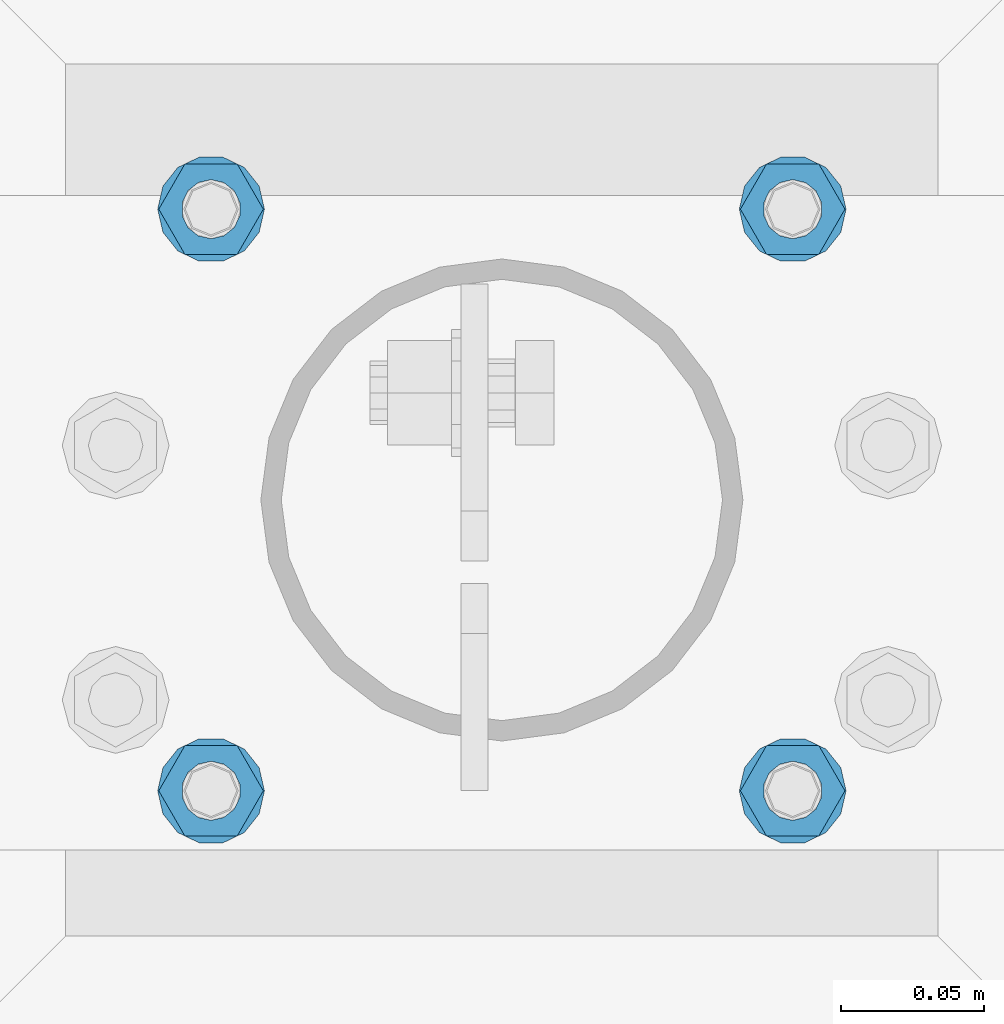
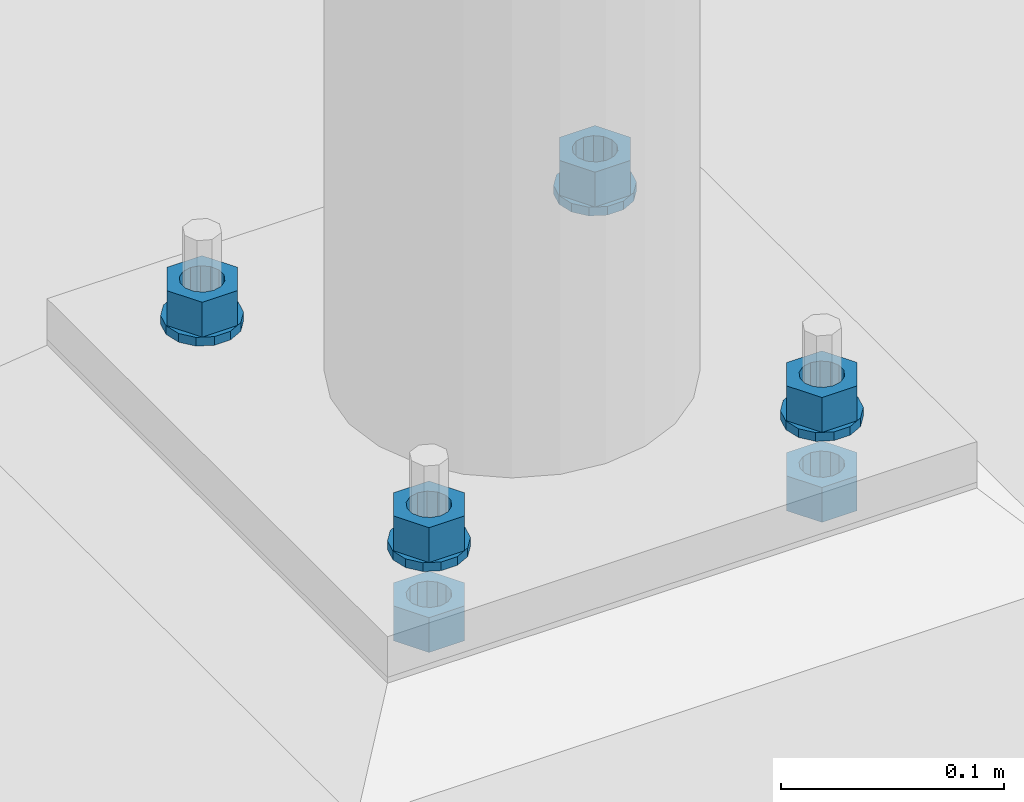
# One storey, part 627 of 975: 10 beams.
"""IFC2X3 building model written with IfcOpenShell, lengths in millimetres."""

import ifcopenshell
import ifcopenshell.guid

model = None  # the IFC model being written
_history = None  # IfcOwnerHistory: only IFC2X3 demands one
_inside = {}  # id of a spatial element -> (the spatial element, [elements in it])
_under = {}  # id of a project, library or spatial element -> (it, [spatial elements below it])
_declared = {}  # id of a project -> (the project, [libraries it declares])
_typed = {}  # id of a type object -> (the type object, [elements of that type])
_made_of = {}  # id of a material, layer set ... -> (it, [elements and type objects made of it])


def new_model(schema):
    """Start an empty IFC model of exactly this schema.

    Asked for "IFC4X3", IfcOpenShell would pick the latest addendum, in which some entities
    have other attributes; the version numbers below select the first issue.
    IFC2X3 requires an IfcOwnerHistory on every rooted entity: one is made here for all.
    """
    global model, _history
    if schema == "IFC4X3":
        model = ifcopenshell.file(schema_version=(4, 3, 0, 0))
    else:
        model = ifcopenshell.file(schema=schema)
    _inside.clear()
    _under.clear()
    _declared.clear()
    _typed.clear()
    _made_of.clear()
    _history = None
    if model.schema == "IFC2X3":
        org = make("IfcOrganization", Name="unknown")
        user = make(
            "IfcPersonAndOrganization",
            ThePerson=make("IfcPerson", FamilyName="unknown"),
            TheOrganization=org,
        )
        app = make(
            "IfcApplication",
            ApplicationDeveloper=org,
            Version="unknown",
            ApplicationFullName="unknown",
            ApplicationIdentifier="unknown",
        )
        _history = make(
            "IfcOwnerHistory",
            OwningUser=user,
            OwningApplication=app,
            ChangeAction="ADDED",
            CreationDate=0,
        )
    return model


def make(cls, **values):
    """One entity of the class cls with the attributes given. An attribute that is None is left unset."""
    return model.create_entity(
        cls, **{name: value for name, value in values.items() if value is not None}
    )


def rooted(cls, **values):
    """An entity with a GlobalId (a new one), such as an element, a storey or a relation."""
    return make(cls, GlobalId=ifcopenshell.guid.new(), OwnerHistory=_history, **values)


def si_unit(unit_type, name, prefix=None):
    """IfcSIUnit, for example si_unit("LENGTHUNIT", "METRE", prefix="MILLI")."""
    return make("IfcSIUnit", UnitType=unit_type, Prefix=prefix, Name=name)


def assignment(units):
    """IfcUnitAssignment: the units of a project."""
    return None if units is None else make("IfcUnitAssignment", Units=units)


def point(xyz):
    """IfcCartesianPoint."""
    return None if xyz is None else make("IfcCartesianPoint", Coordinates=xyz)


def direction(xyz):
    """IfcDirection."""
    return None if xyz is None else make("IfcDirection", DirectionRatios=xyz)


def frame(location, z_axis=None, x_axis=None):
    """IfcAxis2Placement3D, a coordinate frame: its origin and axes. An axis left out is left unset."""
    return make(
        "IfcAxis2Placement3D",
        Location=point(location),
        Axis=direction(z_axis),
        RefDirection=direction(x_axis),
    )


def origin_with_axes():
    """The frame at (0, 0, 0) with the z axis (0, 0, 1) and the x axis (1, 0, 0) written out."""
    return frame((0.0, 0.0, 0.0), z_axis=(0.0, 0.0, 1.0), x_axis=(1.0, 0.0, 0.0))


def place(relative_to, where):
    """IfcLocalPlacement: puts the frame where relative to a parent placement (None: the world)."""
    return make(
        "IfcLocalPlacement", PlacementRelTo=relative_to, RelativePlacement=where
    )


def context(
    kind, dimensions, precision=None, world=None, true_north=None, identifier=None
):
    """IfcGeometricRepresentationContext, for example the 3D "Model" context."""
    return make(
        "IfcGeometricRepresentationContext",
        ContextIdentifier=identifier,
        ContextType=kind,
        CoordinateSpaceDimension=dimensions,
        Precision=precision,
        WorldCoordinateSystem=world,
        TrueNorth=true_north,
    )


def subcontext(parent, identifier, kind, view, scale=None):
    """IfcGeometricRepresentationSubContext, for example "Body" below "Model"."""
    return make(
        "IfcGeometricRepresentationSubContext",
        ContextIdentifier=identifier,
        ContextType=kind,
        ParentContext=parent,
        TargetScale=scale,
        TargetView=view,
    )


def project(units=None, contexts=None):
    """IfcProject with its units and contexts."""
    return rooted(
        "IfcProject",
        Name="project",
        RepresentationContexts=contexts,
        UnitsInContext=assignment(units),
    )


def spatial(cls, under=None, at=None, **own):
    """A site, building, storey or space (cls), placed at a placement, below another one or the project."""
    s = rooted(cls, ObjectPlacement=at, **own)
    if under is not None:
        _under.setdefault(under.id(), (under, []))[1].append(s)
    return s


def faces_of(points, faces, orient=None, outer=None):
    """IfcFace entities. A face is a list of loops; a loop is a list of indices into points, from 0.

    orient and outer hold one flag for each loop. By default every Orientation is true, the
    first loop of a face is its IfcFaceOuterBound and the others are IfcFaceBound.
    """
    made = []
    for i, loops in enumerate(faces):
        bounds = []
        for j, loop in enumerate(loops):
            is_outer = j == 0 if outer is None else outer[i][j]
            bounds.append(
                make(
                    "IfcFaceOuterBound" if is_outer else "IfcFaceBound",
                    Bound=make("IfcPolyLoop", Polygon=[points[k] for k in loop]),
                    Orientation=True if orient is None else orient[i][j],
                )
            )
        made.append(make("IfcFace", Bounds=bounds))
    return made


def faceted_brep(points, faces, orient=None, outer=None, voids=None):
    """IfcFacetedBrep: a solid bounded by flat faces; with voids (closed shells), ...WithVoids."""
    shared = [point(p) for p in points]
    hull = make("IfcClosedShell", CfsFaces=faces_of(shared, faces, orient, outer))
    if voids is None:
        return make("IfcFacetedBrep", Outer=hull)
    return make(
        "IfcFacetedBrepWithVoids",
        Outer=hull,
        Voids=[
            make(cls, CfsFaces=faces_of(shared, fs, o, b)) for cls, fs, o, b in voids
        ],
    )


def shape(context_of_items, identifier, shape_type, items):
    """IfcShapeRepresentation: the items that make up one representation, for example the "Body"."""
    return make(
        "IfcShapeRepresentation",
        ContextOfItems=context_of_items,
        RepresentationIdentifier=identifier,
        RepresentationType=shape_type,
        Items=items,
    )


def material(Name=None, Category=None):
    """IfcMaterial."""
    return make("IfcMaterial", Name=Name, Category=Category)


def made_of(thing, what):
    """Note that an element or type object is made of a material, layer set ...; save() writes the relation."""
    if what is not None:
        _made_of.setdefault(what.id(), (what, []))[1].append(thing)
    return thing


def type_object(cls, material=None, **own):
    """A type object (cls), such as IfcWallType, which elements share."""
    return made_of(rooted(cls, **own), material)


def element(
    cls,
    number,
    at=None,
    inside=None,
    cuts=None,
    type_object=None,
    material=None,
    context=None,
    identifier="Body",
    shape_type=None,
    held_by="IfcProductDefinitionShape",
    body=None,
    shapes=None,
    **own,
):
    """One element of the class cls, such as IfcWall. Its Tag is "e" and its number.

    at: its placement. inside: the storey or other place that contains it. cuts: it is an
    opening in that element (IfcRelVoidsElement). A single representation is given by context,
    identifier, shape_type and body (its items); several are given by shapes. held_by: the class
    of the entity that holds the representations. save() writes the other relations.
    """
    e = rooted(cls, Tag="e%d" % number, ObjectPlacement=at, **own)
    if body is not None:
        shapes = [shape(context, identifier, shape_type, body)]
    if shapes is not None:
        e.Representation = make(held_by, Representations=shapes)
    if inside is not None:
        _inside.setdefault(inside.id(), (inside, []))[1].append(e)
    if cuts is not None:
        rooted(
            "IfcRelVoidsElement", RelatingBuildingElement=cuts, RelatedOpeningElement=e
        )
    if type_object is not None:
        _typed.setdefault(type_object.id(), (type_object, []))[1].append(e)
    return made_of(e, material)


def aggregate(whole, parts):
    """IfcRelAggregates: a whole, such as a stair, and the parts it consists of."""
    return rooted("IfcRelAggregates", RelatingObject=whole, RelatedObjects=parts)


def save(model, path):
    """Write the relations noted so far, then the file.

    IfcRelAggregates (storeys below a building ...), IfcRelContainedInSpatialStructure (elements
    in a storey), IfcRelDefinesByType, IfcRelAssociatesMaterial and IfcRelDeclares: one each for
    every whole, place, type object, material and project.
    """
    for whole, parts in _under.values():
        aggregate(whole, parts)
    for where, things in _inside.values():
        rooted(
            "IfcRelContainedInSpatialStructure",
            RelatedElements=things,
            RelatingStructure=where,
        )
    for kind, things in _typed.values():
        rooted("IfcRelDefinesByType", RelatedObjects=things, RelatingType=kind)
    for what, things in _made_of.values():
        rooted("IfcRelAssociatesMaterial", RelatedObjects=things, RelatingMaterial=what)
    for by, libraries in _declared.values():
        rooted("IfcRelDeclares", RelatingContext=by, RelatedDefinitions=libraries)
    model.write(path)


model = new_model("IFC2X3")

# Units and contexts
model_context = context("Model", 3, precision=1e-05, world=origin_with_axes())
body_context = subcontext(model_context, "Body", "Model", "MODEL_VIEW")
ifc_project = project(units=[si_unit("LENGTHUNIT", "METRE", prefix="MILLI"), si_unit("AREAUNIT", "SQUARE_METRE"), si_unit("VOLUMEUNIT", "CUBIC_METRE"), si_unit("MASSUNIT", "GRAM", prefix="KILO"), si_unit("TIMEUNIT", "SECOND"), si_unit("PLANEANGLEUNIT", "RADIAN"), si_unit("SOLIDANGLEUNIT", "STERADIAN"), si_unit("THERMODYNAMICTEMPERATUREUNIT", "DEGREE_CELSIUS"), si_unit("LUMINOUSINTENSITYUNIT", "LUMEN")], contexts=[model_context])

# Site, building, storey
site_placement = place(None, origin_with_axes())
site = spatial("IfcSite", under=ifc_project, at=site_placement, CompositionType="ELEMENT")
building_placement = place(site_placement, origin_with_axes())
building = spatial("IfcBuilding", under=site, at=building_placement, Name="Undefined", CompositionType="ELEMENT")
storey_placement = place(building_placement, origin_with_axes())
storey = spatial("IfcBuildingStorey", under=building, at=storey_placement, Name="Undefined", CompositionType="ELEMENT", Elevation=0.0)

# Beams
ifc_material = material(Name="STEEL/A36")
beam_type_1 = type_object("IfcBeamType", Name="3/4_WASHER", PredefinedType="NOTDEFINED")
beam_1_placement = place(storey_placement, frame((18757.9000015259, 20545.4250030518, -236.537499999998), z_axis=(0.0, -1.0, 0.0), x_axis=(0.0, 0.0, -1.0)))
element("IfcBeam", 1, at=beam_1_placement, inside=storey, type_object=beam_type_1, material=ifc_material, Name="WASHER", ObjectType="3/4_WASHER", context=body_context, shape_type="Brep", body=[
    faceted_brep([(0.0, -18.6499996185303, 0.0), (0.0, -16.8030690426876, -8.09193156902904), (4.76250000000073, -16.8030690426876, -8.09193156902904), (4.76250000000073, -18.6499996185303, 0.0), (0.0, -11.6280845668225, -14.5811568497838), (4.76250000000073, -11.6280845668225, -14.5811568497838), (0.0, -4.15001533340001, -18.1824051902857), (4.76250000000073, -4.15001533340001, -18.1824051902857), (0.0, 4.15001533340001, -18.1824051902857), (4.76250000000073, 4.15001533340001, -18.1824051902857), (0.0, 11.6280845668234, -14.5811568497838), (4.76250000000073, 11.6280845668234, -14.5811568497838), (0.0, 16.8030690426876, -8.09193156902904), (4.76250000000073, 16.8030690426876, -8.09193156902904), (0.0, 18.6499996185303, 0.0), (4.76250000000073, 18.6499996185303, 0.0), (0.0, 16.8030690426876, 8.09193156902904), (4.76250000000073, 16.8030690426876, 8.09193156902904), (0.0, 11.6280845668225, 14.5811568497838), (4.76250000000073, 11.6280845668225, 14.5811568497838), (0.0, 4.15001533340001, 18.1824051902857), (4.76250000000073, 4.15001533340001, 18.1824051902857), (0.0, -4.15001533340001, 18.1824051902857), (4.76250000000073, -4.15001533340001, 18.1824051902857), (0.0, -11.6280845668234, 14.5811568497838), (4.76250000000073, -11.6280845668234, 14.5811568497838), (0.0, -16.8030690426876, 8.09193156902904), (4.76250000000073, -16.8030690426876, 8.09193156902904), (0.0, 0.0, 10.3199996948242), (0.0, 4.47768005528269, 9.29799844179911), (4.76250000000073, 4.47768005528269, 9.29799844179911), (4.76250000000073, 0.0, 10.3199996948242), (0.0, 8.06850066047446, 6.43441456490817), (4.76250000000073, 8.06850066047446, 6.43441456490817), (0.0, 10.0612557561917, 2.29641597052117), (4.76250000000073, 10.0612557561917, 2.29641597052117), (0.0, 10.0612557561917, -2.29641597052117), (4.76250000000073, 10.0612557561917, -2.29641597052117), (0.0, 8.06850066047446, -6.43441456490814), (4.76250000000073, 8.06850066047446, -6.43441456490814), (0.0, 4.47768005528269, -9.29799844179908), (4.76250000000073, 4.47768005528269, -9.29799844179908), (0.0, 0.0, -10.3199996948242), (4.76250000000073, 0.0, -10.3199996948242), (0.0, -4.47768005528269, -9.29799844179911), (4.76250000000073, -4.47768005528269, -9.29799844179911), (0.0, -8.06850066047446, -6.43441456490817), (4.76250000000073, -8.06850066047446, -6.43441456490817), (0.0, -10.0612557561917, -2.29641597052117), (4.76250000000073, -10.0612557561917, -2.29641597052117), (0.0, -10.0612557561917, 2.29641597052117), (4.76250000000073, -10.0612557561917, 2.29641597052117), (0.0, -8.06850066047446, 6.43441456490814), (4.76250000000073, -8.06850066047446, 6.43441456490814), (0.0, -4.47768005528269, 9.29799844179908), (4.76250000000073, -4.47768005528269, 9.29799844179908)], [[[0, 1, 2, 3]], [[1, 4, 5, 2]], [[4, 6, 7, 5]], [[6, 8, 9, 7]], [[8, 10, 11, 9]], [[10, 12, 13, 11]], [[12, 14, 15, 13]], [[14, 16, 17, 15]], [[16, 18, 19, 17]], [[18, 20, 21, 19]], [[20, 22, 23, 21]], [[22, 24, 25, 23]], [[24, 26, 27, 25]], [[26, 0, 3, 27]], [[28, 29, 30, 31]], [[29, 32, 33, 30]], [[32, 34, 35, 33]], [[34, 36, 37, 35]], [[36, 38, 39, 37]], [[38, 40, 41, 39]], [[40, 42, 43, 41]], [[42, 44, 45, 43]], [[44, 46, 47, 45]], [[46, 48, 49, 47]], [[48, 50, 51, 49]], [[50, 52, 53, 51]], [[52, 54, 55, 53]], [[54, 28, 31, 55]], [[5, 7, 9, 11, 13, 15, 17, 19, 21, 23, 25, 27, 3, 2], [33, 35, 37, 39, 41, 43, 45, 47, 49, 51, 53, 55, 31, 30]], [[26, 24, 22, 20, 18, 16, 14, 12, 10, 8, 6, 4, 1, 0], [54, 52, 50, 48, 46, 44, 42, 40, 38, 36, 34, 32, 29, 28]]]),
])
beam_2_placement = place(storey_placement, frame((18961.0999984741, 20545.4250030518, -236.537499999998), z_axis=(0.0, 1.0, 0.0), x_axis=(0.0, 0.0, -1.0)))
element("IfcBeam", 2, at=beam_2_placement, inside=storey, type_object=beam_type_1, material=ifc_material, Name="WASHER", ObjectType="3/4_WASHER", context=body_context, shape_type="Brep", body=[
    faceted_brep([(0.0, -18.6499996185303, 0.0), (0.0, -16.8030690426876, -8.09193156902904), (4.76250000000073, -16.8030690426876, -8.09193156902904), (4.76250000000073, -18.6499996185303, 0.0), (0.0, -11.6280845668225, -14.5811568497838), (4.76250000000073, -11.6280845668225, -14.5811568497838), (0.0, -4.15001533340001, -18.1824051902857), (4.76250000000073, -4.15001533340001, -18.1824051902857), (0.0, 4.15001533340001, -18.1824051902857), (4.76250000000073, 4.15001533340001, -18.1824051902857), (0.0, 11.6280845668234, -14.5811568497838), (4.76250000000073, 11.6280845668234, -14.5811568497838), (0.0, 16.8030690426876, -8.09193156902904), (4.76250000000073, 16.8030690426876, -8.09193156902904), (0.0, 18.6499996185303, 0.0), (4.76250000000073, 18.6499996185303, 0.0), (0.0, 16.8030690426876, 8.09193156902904), (4.76250000000073, 16.8030690426876, 8.09193156902904), (0.0, 11.6280845668225, 14.5811568497838), (4.76250000000073, 11.6280845668225, 14.5811568497838), (0.0, 4.15001533340001, 18.1824051902857), (4.76250000000073, 4.15001533340001, 18.1824051902857), (0.0, -4.15001533340001, 18.1824051902857), (4.76250000000073, -4.15001533340001, 18.1824051902857), (0.0, -11.6280845668234, 14.5811568497838), (4.76250000000073, -11.6280845668234, 14.5811568497838), (0.0, -16.8030690426876, 8.09193156902904), (4.76250000000073, -16.8030690426876, 8.09193156902904), (0.0, 0.0, 10.3199996948242), (0.0, 4.47768005528269, 9.29799844179911), (4.76250000000073, 4.47768005528269, 9.29799844179911), (4.76250000000073, 0.0, 10.3199996948242), (0.0, 8.06850066047446, 6.43441456490817), (4.76250000000073, 8.06850066047446, 6.43441456490817), (0.0, 10.0612557561917, 2.29641597052117), (4.76250000000073, 10.0612557561917, 2.29641597052117), (0.0, 10.0612557561917, -2.29641597052117), (4.76250000000073, 10.0612557561917, -2.29641597052117), (0.0, 8.06850066047446, -6.43441456490814), (4.76250000000073, 8.06850066047446, -6.43441456490814), (0.0, 4.47768005528269, -9.29799844179908), (4.76250000000073, 4.47768005528269, -9.29799844179908), (0.0, 0.0, -10.3199996948242), (4.76250000000073, 0.0, -10.3199996948242), (0.0, -4.47768005528269, -9.29799844179911), (4.76250000000073, -4.47768005528269, -9.29799844179911), (0.0, -8.06850066047446, -6.43441456490817), (4.76250000000073, -8.06850066047446, -6.43441456490817), (0.0, -10.0612557561917, -2.29641597052117), (4.76250000000073, -10.0612557561917, -2.29641597052117), (0.0, -10.0612557561917, 2.29641597052117), (4.76250000000073, -10.0612557561917, 2.29641597052117), (0.0, -8.06850066047446, 6.43441456490814), (4.76250000000073, -8.06850066047446, 6.43441456490814), (0.0, -4.47768005528269, 9.29799844179908), (4.76250000000073, -4.47768005528269, 9.29799844179908)], [[[0, 1, 2, 3]], [[1, 4, 5, 2]], [[4, 6, 7, 5]], [[6, 8, 9, 7]], [[8, 10, 11, 9]], [[10, 12, 13, 11]], [[12, 14, 15, 13]], [[14, 16, 17, 15]], [[16, 18, 19, 17]], [[18, 20, 21, 19]], [[20, 22, 23, 21]], [[22, 24, 25, 23]], [[24, 26, 27, 25]], [[26, 0, 3, 27]], [[28, 29, 30, 31]], [[29, 32, 33, 30]], [[32, 34, 35, 33]], [[34, 36, 37, 35]], [[36, 38, 39, 37]], [[38, 40, 41, 39]], [[40, 42, 43, 41]], [[42, 44, 45, 43]], [[44, 46, 47, 45]], [[46, 48, 49, 47]], [[48, 50, 51, 49]], [[50, 52, 53, 51]], [[52, 54, 55, 53]], [[54, 28, 31, 55]], [[5, 7, 9, 11, 13, 15, 17, 19, 21, 23, 25, 27, 3, 2], [33, 35, 37, 39, 41, 43, 45, 47, 49, 51, 53, 55, 31, 30]], [[26, 24, 22, 20, 18, 16, 14, 12, 10, 8, 6, 4, 1, 0], [54, 52, 50, 48, 46, 44, 42, 40, 38, 36, 34, 32, 29, 28]]]),
])
beam_3_placement = place(storey_placement, frame((18757.9000015259, 20748.625, -236.537499999998), z_axis=(0.0, -1.0, 0.0), x_axis=(0.0, 0.0, -1.0)))
element("IfcBeam", 3, at=beam_3_placement, inside=storey, type_object=beam_type_1, material=ifc_material, Name="WASHER", ObjectType="3/4_WASHER", context=body_context, shape_type="Brep", body=[
    faceted_brep([(0.0, -18.6499996185303, 0.0), (0.0, -16.8030690426876, -8.09193156902904), (4.76250000000073, -16.8030690426876, -8.09193156902904), (4.76250000000073, -18.6499996185303, 0.0), (0.0, -11.6280845668225, -14.5811568497838), (4.76250000000073, -11.6280845668225, -14.5811568497838), (0.0, -4.15001533340001, -18.1824051902857), (4.76250000000073, -4.15001533340001, -18.1824051902857), (0.0, 4.15001533340001, -18.1824051902857), (4.76250000000073, 4.15001533340001, -18.1824051902857), (0.0, 11.6280845668234, -14.5811568497838), (4.76250000000073, 11.6280845668234, -14.5811568497838), (0.0, 16.8030690426876, -8.09193156902904), (4.76250000000073, 16.8030690426876, -8.09193156902904), (0.0, 18.6499996185303, 0.0), (4.76250000000073, 18.6499996185303, 0.0), (0.0, 16.8030690426876, 8.09193156902904), (4.76250000000073, 16.8030690426876, 8.09193156902904), (0.0, 11.6280845668225, 14.5811568497838), (4.76250000000073, 11.6280845668225, 14.5811568497838), (0.0, 4.15001533340001, 18.1824051902857), (4.76250000000073, 4.15001533340001, 18.1824051902857), (0.0, -4.15001533340001, 18.1824051902857), (4.76250000000073, -4.15001533340001, 18.1824051902857), (0.0, -11.6280845668234, 14.5811568497838), (4.76250000000073, -11.6280845668234, 14.5811568497838), (0.0, -16.8030690426876, 8.09193156902904), (4.76250000000073, -16.8030690426876, 8.09193156902904), (0.0, 0.0, 10.3199996948242), (0.0, 4.47768005528269, 9.29799844179911), (4.76250000000073, 4.47768005528269, 9.29799844179911), (4.76250000000073, 0.0, 10.3199996948242), (0.0, 8.06850066047446, 6.43441456490817), (4.76250000000073, 8.06850066047446, 6.43441456490817), (0.0, 10.0612557561917, 2.29641597052117), (4.76250000000073, 10.0612557561917, 2.29641597052117), (0.0, 10.0612557561917, -2.29641597052117), (4.76250000000073, 10.0612557561917, -2.29641597052117), (0.0, 8.06850066047446, -6.43441456490814), (4.76250000000073, 8.06850066047446, -6.43441456490814), (0.0, 4.47768005528269, -9.29799844179908), (4.76250000000073, 4.47768005528269, -9.29799844179908), (0.0, 0.0, -10.3199996948242), (4.76250000000073, 0.0, -10.3199996948242), (0.0, -4.47768005528269, -9.29799844179911), (4.76250000000073, -4.47768005528269, -9.29799844179911), (0.0, -8.06850066047446, -6.43441456490817), (4.76250000000073, -8.06850066047446, -6.43441456490817), (0.0, -10.0612557561917, -2.29641597052117), (4.76250000000073, -10.0612557561917, -2.29641597052117), (0.0, -10.0612557561917, 2.29641597052117), (4.76250000000073, -10.0612557561917, 2.29641597052117), (0.0, -8.06850066047446, 6.43441456490814), (4.76250000000073, -8.06850066047446, 6.43441456490814), (0.0, -4.47768005528269, 9.29799844179908), (4.76250000000073, -4.47768005528269, 9.29799844179908)], [[[0, 1, 2, 3]], [[1, 4, 5, 2]], [[4, 6, 7, 5]], [[6, 8, 9, 7]], [[8, 10, 11, 9]], [[10, 12, 13, 11]], [[12, 14, 15, 13]], [[14, 16, 17, 15]], [[16, 18, 19, 17]], [[18, 20, 21, 19]], [[20, 22, 23, 21]], [[22, 24, 25, 23]], [[24, 26, 27, 25]], [[26, 0, 3, 27]], [[28, 29, 30, 31]], [[29, 32, 33, 30]], [[32, 34, 35, 33]], [[34, 36, 37, 35]], [[36, 38, 39, 37]], [[38, 40, 41, 39]], [[40, 42, 43, 41]], [[42, 44, 45, 43]], [[44, 46, 47, 45]], [[46, 48, 49, 47]], [[48, 50, 51, 49]], [[50, 52, 53, 51]], [[52, 54, 55, 53]], [[54, 28, 31, 55]], [[5, 7, 9, 11, 13, 15, 17, 19, 21, 23, 25, 27, 3, 2], [33, 35, 37, 39, 41, 43, 45, 47, 49, 51, 53, 55, 31, 30]], [[26, 24, 22, 20, 18, 16, 14, 12, 10, 8, 6, 4, 1, 0], [54, 52, 50, 48, 46, 44, 42, 40, 38, 36, 34, 32, 29, 28]]]),
])
beam_4_placement = place(storey_placement, frame((18961.0999984741, 20748.625, -236.537499999998), z_axis=(0.0, 1.0, 0.0), x_axis=(0.0, 0.0, -1.0)))
element("IfcBeam", 4, at=beam_4_placement, inside=storey, type_object=beam_type_1, material=ifc_material, Name="WASHER", ObjectType="3/4_WASHER", context=body_context, shape_type="Brep", body=[
    faceted_brep([(0.0, -18.6499996185303, 0.0), (0.0, -16.8030690426876, -8.09193156902904), (4.76250000000073, -16.8030690426876, -8.09193156902904), (4.76250000000073, -18.6499996185303, 0.0), (0.0, -11.6280845668225, -14.5811568497838), (4.76250000000073, -11.6280845668225, -14.5811568497838), (0.0, -4.15001533340001, -18.1824051902857), (4.76250000000073, -4.15001533340001, -18.1824051902857), (0.0, 4.15001533340001, -18.1824051902857), (4.76250000000073, 4.15001533340001, -18.1824051902857), (0.0, 11.6280845668234, -14.5811568497838), (4.76250000000073, 11.6280845668234, -14.5811568497838), (0.0, 16.8030690426876, -8.09193156902904), (4.76250000000073, 16.8030690426876, -8.09193156902904), (0.0, 18.6499996185303, 0.0), (4.76250000000073, 18.6499996185303, 0.0), (0.0, 16.8030690426876, 8.09193156902904), (4.76250000000073, 16.8030690426876, 8.09193156902904), (0.0, 11.6280845668225, 14.5811568497838), (4.76250000000073, 11.6280845668225, 14.5811568497838), (0.0, 4.15001533340001, 18.1824051902857), (4.76250000000073, 4.15001533340001, 18.1824051902857), (0.0, -4.15001533340001, 18.1824051902857), (4.76250000000073, -4.15001533340001, 18.1824051902857), (0.0, -11.6280845668234, 14.5811568497838), (4.76250000000073, -11.6280845668234, 14.5811568497838), (0.0, -16.8030690426876, 8.09193156902904), (4.76250000000073, -16.8030690426876, 8.09193156902904), (0.0, 0.0, 10.3199996948242), (0.0, 4.47768005528269, 9.29799844179911), (4.76250000000073, 4.47768005528269, 9.29799844179911), (4.76250000000073, 0.0, 10.3199996948242), (0.0, 8.06850066047446, 6.43441456490817), (4.76250000000073, 8.06850066047446, 6.43441456490817), (0.0, 10.0612557561917, 2.29641597052117), (4.76250000000073, 10.0612557561917, 2.29641597052117), (0.0, 10.0612557561917, -2.29641597052117), (4.76250000000073, 10.0612557561917, -2.29641597052117), (0.0, 8.06850066047446, -6.43441456490814), (4.76250000000073, 8.06850066047446, -6.43441456490814), (0.0, 4.47768005528269, -9.29799844179908), (4.76250000000073, 4.47768005528269, -9.29799844179908), (0.0, 0.0, -10.3199996948242), (4.76250000000073, 0.0, -10.3199996948242), (0.0, -4.47768005528269, -9.29799844179911), (4.76250000000073, -4.47768005528269, -9.29799844179911), (0.0, -8.06850066047446, -6.43441456490817), (4.76250000000073, -8.06850066047446, -6.43441456490817), (0.0, -10.0612557561917, -2.29641597052117), (4.76250000000073, -10.0612557561917, -2.29641597052117), (0.0, -10.0612557561917, 2.29641597052117), (4.76250000000073, -10.0612557561917, 2.29641597052117), (0.0, -8.06850066047446, 6.43441456490814), (4.76250000000073, -8.06850066047446, 6.43441456490814), (0.0, -4.47768005528269, 9.29799844179908), (4.76250000000073, -4.47768005528269, 9.29799844179908)], [[[0, 1, 2, 3]], [[1, 4, 5, 2]], [[4, 6, 7, 5]], [[6, 8, 9, 7]], [[8, 10, 11, 9]], [[10, 12, 13, 11]], [[12, 14, 15, 13]], [[14, 16, 17, 15]], [[16, 18, 19, 17]], [[18, 20, 21, 19]], [[20, 22, 23, 21]], [[22, 24, 25, 23]], [[24, 26, 27, 25]], [[26, 0, 3, 27]], [[28, 29, 30, 31]], [[29, 32, 33, 30]], [[32, 34, 35, 33]], [[34, 36, 37, 35]], [[36, 38, 39, 37]], [[38, 40, 41, 39]], [[40, 42, 43, 41]], [[42, 44, 45, 43]], [[44, 46, 47, 45]], [[46, 48, 49, 47]], [[48, 50, 51, 49]], [[50, 52, 53, 51]], [[52, 54, 55, 53]], [[54, 28, 31, 55]], [[5, 7, 9, 11, 13, 15, 17, 19, 21, 23, 25, 27, 3, 2], [33, 35, 37, 39, 41, 43, 45, 47, 49, 51, 53, 55, 31, 30]], [[26, 24, 22, 20, 18, 16, 14, 12, 10, 8, 6, 4, 1, 0], [54, 52, 50, 48, 46, 44, 42, 40, 38, 36, 34, 32, 29, 28]]]),
])
beam_type_2 = type_object("IfcBeamType", Name="3/4_HEAVY_HEX_NUT", PredefinedType="NOTDEFINED")
beam_5_placement = place(storey_placement, frame((18757.9000015259, 20545.4250030518, -217.487499999999), z_axis=(0.0, -1.0, 0.0), x_axis=(0.0, 0.0, -1.0)))
element("IfcBeam", 5, at=beam_5_placement, inside=storey, type_object=beam_type_2, material=ifc_material, Name="NUT", ObjectType="3/4_HEAVY_HEX_NUT", context=body_context, shape_type="Brep", body=[
    faceted_brep([(0.0, -18.2600002288818, 0.0), (0.0, -9.13000011444092, -15.8100004196167), (19.0499999999993, -9.13000011444092, -15.8100004196167), (19.0499999999993, -18.2600002288818, 0.0), (0.0, 9.13000011444092, -15.8100004196167), (19.0499999999993, 9.13000011444092, -15.8100004196167), (0.0, 18.2600002288818, 0.0), (19.0499999999993, 18.2600002288818, 0.0), (0.0, 9.13000011444092, 15.8100004196167), (19.0499999999993, 9.13000011444092, 15.8100004196167), (0.0, -9.13000011444092, 15.8100004196167), (19.0499999999993, -9.13000011444092, 15.8100004196167), (0.0, 0.0, 10.3199996948242), (0.0, 4.47768005528269, 9.29799844179911), (19.0499999999993, 4.47768005528269, 9.29799844179911), (19.0499999999993, 0.0, 10.3199996948242), (0.0, 8.06850066047446, 6.43441456490817), (19.0499999999993, 8.06850066047446, 6.43441456490817), (0.0, 10.0612557561917, 2.29641597052117), (19.0499999999993, 10.0612557561917, 2.29641597052117), (0.0, 10.0612557561917, -2.29641597052117), (19.0499999999993, 10.0612557561917, -2.29641597052117), (0.0, 8.06850066047446, -6.43441456490814), (19.0499999999993, 8.06850066047446, -6.43441456490814), (0.0, 4.47768005528269, -9.29799844179908), (19.0499999999993, 4.47768005528269, -9.29799844179908), (0.0, 0.0, -10.3199996948242), (19.0499999999993, 0.0, -10.3199996948242), (0.0, -4.47768005528269, -9.29799844179911), (19.0499999999993, -4.47768005528269, -9.29799844179911), (0.0, -8.06850066047446, -6.43441456490817), (19.0499999999993, -8.06850066047446, -6.43441456490817), (0.0, -10.0612557561917, -2.29641597052117), (19.0499999999993, -10.0612557561917, -2.29641597052117), (0.0, -10.0612557561917, 2.29641597052117), (19.0499999999993, -10.0612557561917, 2.29641597052117), (0.0, -8.06850066047446, 6.43441456490814), (19.0499999999993, -8.06850066047446, 6.43441456490814), (0.0, -4.47768005528269, 9.29799844179908), (19.0499999999993, -4.47768005528269, 9.29799844179908)], [[[0, 1, 2, 3]], [[1, 4, 5, 2]], [[4, 6, 7, 5]], [[6, 8, 9, 7]], [[8, 10, 11, 9]], [[10, 0, 3, 11]], [[12, 13, 14, 15]], [[13, 16, 17, 14]], [[16, 18, 19, 17]], [[18, 20, 21, 19]], [[20, 22, 23, 21]], [[22, 24, 25, 23]], [[24, 26, 27, 25]], [[26, 28, 29, 27]], [[28, 30, 31, 29]], [[30, 32, 33, 31]], [[32, 34, 35, 33]], [[34, 36, 37, 35]], [[36, 38, 39, 37]], [[38, 12, 15, 39]], [[5, 7, 9, 11, 3, 2], [17, 19, 21, 23, 25, 27, 29, 31, 33, 35, 37, 39, 15, 14]], [[10, 8, 6, 4, 1, 0], [38, 36, 34, 32, 30, 28, 26, 24, 22, 20, 18, 16, 13, 12]]]),
])
beam_6_placement = place(storey_placement, frame((18961.0999984741, 20545.4250030518, -217.487499999999), z_axis=(0.0, 1.0, 0.0), x_axis=(0.0, 0.0, -1.0)))
element("IfcBeam", 6, at=beam_6_placement, inside=storey, type_object=beam_type_2, material=ifc_material, Name="NUT", ObjectType="3/4_HEAVY_HEX_NUT", context=body_context, shape_type="Brep", body=[
    faceted_brep([(0.0, -18.2600002288818, 0.0), (0.0, -9.13000011444092, -15.8100004196167), (19.0499999999993, -9.13000011444092, -15.8100004196167), (19.0499999999993, -18.2600002288818, 0.0), (0.0, 9.13000011444092, -15.8100004196167), (19.0499999999993, 9.13000011444092, -15.8100004196167), (0.0, 18.2600002288818, 0.0), (19.0499999999993, 18.2600002288818, 0.0), (0.0, 9.13000011444092, 15.8100004196167), (19.0499999999993, 9.13000011444092, 15.8100004196167), (0.0, -9.13000011444092, 15.8100004196167), (19.0499999999993, -9.13000011444092, 15.8100004196167), (0.0, 0.0, 10.3199996948242), (0.0, 4.47768005528269, 9.29799844179911), (19.0499999999993, 4.47768005528269, 9.29799844179911), (19.0499999999993, 0.0, 10.3199996948242), (0.0, 8.06850066047446, 6.43441456490817), (19.0499999999993, 8.06850066047446, 6.43441456490817), (0.0, 10.0612557561917, 2.29641597052117), (19.0499999999993, 10.0612557561917, 2.29641597052117), (0.0, 10.0612557561917, -2.29641597052117), (19.0499999999993, 10.0612557561917, -2.29641597052117), (0.0, 8.06850066047446, -6.43441456490814), (19.0499999999993, 8.06850066047446, -6.43441456490814), (0.0, 4.47768005528269, -9.29799844179908), (19.0499999999993, 4.47768005528269, -9.29799844179908), (0.0, 0.0, -10.3199996948242), (19.0499999999993, 0.0, -10.3199996948242), (0.0, -4.47768005528269, -9.29799844179911), (19.0499999999993, -4.47768005528269, -9.29799844179911), (0.0, -8.06850066047446, -6.43441456490817), (19.0499999999993, -8.06850066047446, -6.43441456490817), (0.0, -10.0612557561917, -2.29641597052117), (19.0499999999993, -10.0612557561917, -2.29641597052117), (0.0, -10.0612557561917, 2.29641597052117), (19.0499999999993, -10.0612557561917, 2.29641597052117), (0.0, -8.06850066047446, 6.43441456490814), (19.0499999999993, -8.06850066047446, 6.43441456490814), (0.0, -4.47768005528269, 9.29799844179908), (19.0499999999993, -4.47768005528269, 9.29799844179908)], [[[0, 1, 2, 3]], [[1, 4, 5, 2]], [[4, 6, 7, 5]], [[6, 8, 9, 7]], [[8, 10, 11, 9]], [[10, 0, 3, 11]], [[12, 13, 14, 15]], [[13, 16, 17, 14]], [[16, 18, 19, 17]], [[18, 20, 21, 19]], [[20, 22, 23, 21]], [[22, 24, 25, 23]], [[24, 26, 27, 25]], [[26, 28, 29, 27]], [[28, 30, 31, 29]], [[30, 32, 33, 31]], [[32, 34, 35, 33]], [[34, 36, 37, 35]], [[36, 38, 39, 37]], [[38, 12, 15, 39]], [[5, 7, 9, 11, 3, 2], [17, 19, 21, 23, 25, 27, 29, 31, 33, 35, 37, 39, 15, 14]], [[10, 8, 6, 4, 1, 0], [38, 36, 34, 32, 30, 28, 26, 24, 22, 20, 18, 16, 13, 12]]]),
])
beam_7_placement = place(storey_placement, frame((18757.9000015259, 20748.625, -217.487499999999), z_axis=(0.0, -1.0, 0.0), x_axis=(0.0, 0.0, -1.0)))
element("IfcBeam", 7, at=beam_7_placement, inside=storey, type_object=beam_type_2, material=ifc_material, Name="NUT", ObjectType="3/4_HEAVY_HEX_NUT", context=body_context, shape_type="Brep", body=[
    faceted_brep([(0.0, -18.2600002288818, 0.0), (0.0, -9.13000011444092, -15.8100004196167), (19.0499999999993, -9.13000011444092, -15.8100004196167), (19.0499999999993, -18.2600002288818, 0.0), (0.0, 9.13000011444092, -15.8100004196167), (19.0499999999993, 9.13000011444092, -15.8100004196167), (0.0, 18.2600002288818, 0.0), (19.0499999999993, 18.2600002288818, 0.0), (0.0, 9.13000011444092, 15.8100004196167), (19.0499999999993, 9.13000011444092, 15.8100004196167), (0.0, -9.13000011444092, 15.8100004196167), (19.0499999999993, -9.13000011444092, 15.8100004196167), (0.0, 0.0, 10.3199996948242), (0.0, 4.47768005528269, 9.29799844179911), (19.0499999999993, 4.47768005528269, 9.29799844179911), (19.0499999999993, 0.0, 10.3199996948242), (0.0, 8.06850066047446, 6.43441456490817), (19.0499999999993, 8.06850066047446, 6.43441456490817), (0.0, 10.0612557561917, 2.29641597052117), (19.0499999999993, 10.0612557561917, 2.29641597052117), (0.0, 10.0612557561917, -2.29641597052117), (19.0499999999993, 10.0612557561917, -2.29641597052117), (0.0, 8.06850066047446, -6.43441456490814), (19.0499999999993, 8.06850066047446, -6.43441456490814), (0.0, 4.47768005528269, -9.29799844179908), (19.0499999999993, 4.47768005528269, -9.29799844179908), (0.0, 0.0, -10.3199996948242), (19.0499999999993, 0.0, -10.3199996948242), (0.0, -4.47768005528269, -9.29799844179911), (19.0499999999993, -4.47768005528269, -9.29799844179911), (0.0, -8.06850066047446, -6.43441456490817), (19.0499999999993, -8.06850066047446, -6.43441456490817), (0.0, -10.0612557561917, -2.29641597052117), (19.0499999999993, -10.0612557561917, -2.29641597052117), (0.0, -10.0612557561917, 2.29641597052117), (19.0499999999993, -10.0612557561917, 2.29641597052117), (0.0, -8.06850066047446, 6.43441456490814), (19.0499999999993, -8.06850066047446, 6.43441456490814), (0.0, -4.47768005528269, 9.29799844179908), (19.0499999999993, -4.47768005528269, 9.29799844179908)], [[[0, 1, 2, 3]], [[1, 4, 5, 2]], [[4, 6, 7, 5]], [[6, 8, 9, 7]], [[8, 10, 11, 9]], [[10, 0, 3, 11]], [[12, 13, 14, 15]], [[13, 16, 17, 14]], [[16, 18, 19, 17]], [[18, 20, 21, 19]], [[20, 22, 23, 21]], [[22, 24, 25, 23]], [[24, 26, 27, 25]], [[26, 28, 29, 27]], [[28, 30, 31, 29]], [[30, 32, 33, 31]], [[32, 34, 35, 33]], [[34, 36, 37, 35]], [[36, 38, 39, 37]], [[38, 12, 15, 39]], [[5, 7, 9, 11, 3, 2], [17, 19, 21, 23, 25, 27, 29, 31, 33, 35, 37, 39, 15, 14]], [[10, 8, 6, 4, 1, 0], [38, 36, 34, 32, 30, 28, 26, 24, 22, 20, 18, 16, 13, 12]]]),
])
beam_8_placement = place(storey_placement, frame((18961.0999984741, 20748.625, -217.487499999999), z_axis=(0.0, 1.0, 0.0), x_axis=(0.0, 0.0, -1.0)))
element("IfcBeam", 8, at=beam_8_placement, inside=storey, type_object=beam_type_2, material=ifc_material, Name="NUT", ObjectType="3/4_HEAVY_HEX_NUT", context=body_context, shape_type="Brep", body=[
    faceted_brep([(0.0, -18.2600002288818, 0.0), (0.0, -9.13000011444092, -15.8100004196167), (19.0499999999993, -9.13000011444092, -15.8100004196167), (19.0499999999993, -18.2600002288818, 0.0), (0.0, 9.13000011444092, -15.8100004196167), (19.0499999999993, 9.13000011444092, -15.8100004196167), (0.0, 18.2600002288818, 0.0), (19.0499999999993, 18.2600002288818, 0.0), (0.0, 9.13000011444092, 15.8100004196167), (19.0499999999993, 9.13000011444092, 15.8100004196167), (0.0, -9.13000011444092, 15.8100004196167), (19.0499999999993, -9.13000011444092, 15.8100004196167), (0.0, 0.0, 10.3199996948242), (0.0, 4.47768005528269, 9.29799844179911), (19.0499999999993, 4.47768005528269, 9.29799844179911), (19.0499999999993, 0.0, 10.3199996948242), (0.0, 8.06850066047446, 6.43441456490817), (19.0499999999993, 8.06850066047446, 6.43441456490817), (0.0, 10.0612557561917, 2.29641597052117), (19.0499999999993, 10.0612557561917, 2.29641597052117), (0.0, 10.0612557561917, -2.29641597052117), (19.0499999999993, 10.0612557561917, -2.29641597052117), (0.0, 8.06850066047446, -6.43441456490814), (19.0499999999993, 8.06850066047446, -6.43441456490814), (0.0, 4.47768005528269, -9.29799844179908), (19.0499999999993, 4.47768005528269, -9.29799844179908), (0.0, 0.0, -10.3199996948242), (19.0499999999993, 0.0, -10.3199996948242), (0.0, -4.47768005528269, -9.29799844179911), (19.0499999999993, -4.47768005528269, -9.29799844179911), (0.0, -8.06850066047446, -6.43441456490817), (19.0499999999993, -8.06850066047446, -6.43441456490817), (0.0, -10.0612557561917, -2.29641597052117), (19.0499999999993, -10.0612557561917, -2.29641597052117), (0.0, -10.0612557561917, 2.29641597052117), (19.0499999999993, -10.0612557561917, 2.29641597052117), (0.0, -8.06850066047446, 6.43441456490814), (19.0499999999993, -8.06850066047446, 6.43441456490814), (0.0, -4.47768005528269, 9.29799844179908), (19.0499999999993, -4.47768005528269, 9.29799844179908)], [[[0, 1, 2, 3]], [[1, 4, 5, 2]], [[4, 6, 7, 5]], [[6, 8, 9, 7]], [[8, 10, 11, 9]], [[10, 0, 3, 11]], [[12, 13, 14, 15]], [[13, 16, 17, 14]], [[16, 18, 19, 17]], [[18, 20, 21, 19]], [[20, 22, 23, 21]], [[22, 24, 25, 23]], [[24, 26, 27, 25]], [[26, 28, 29, 27]], [[28, 30, 31, 29]], [[30, 32, 33, 31]], [[32, 34, 35, 33]], [[34, 36, 37, 35]], [[36, 38, 39, 37]], [[38, 12, 15, 39]], [[5, 7, 9, 11, 3, 2], [17, 19, 21, 23, 25, 27, 29, 31, 33, 35, 37, 39, 15, 14]], [[10, 8, 6, 4, 1, 0], [38, 36, 34, 32, 30, 28, 26, 24, 22, 20, 18, 16, 13, 12]]]),
])
beam_9_placement = place(storey_placement, frame((18757.9000015259, 20545.4250030518, -266.7), z_axis=(0.0, -1.0, 0.0), x_axis=(0.0, 0.0, -1.0)))
element("IfcBeam", 9, at=beam_9_placement, inside=storey, type_object=beam_type_2, material=ifc_material, Name="NUT", ObjectType="3/4_HEAVY_HEX_NUT", context=body_context, shape_type="Brep", body=[
    faceted_brep([(0.0, -18.2600002288818, 0.0), (0.0, -9.13000011444092, -15.8100004196167), (19.0499999999993, -9.13000011444092, -15.8100004196167), (19.0499999999993, -18.2600002288818, 0.0), (0.0, 9.13000011444092, -15.8100004196167), (19.0499999999993, 9.13000011444092, -15.8100004196167), (0.0, 18.2600002288818, 0.0), (19.0499999999993, 18.2600002288818, 0.0), (0.0, 9.13000011444092, 15.8100004196167), (19.0499999999993, 9.13000011444092, 15.8100004196167), (0.0, -9.13000011444092, 15.8100004196167), (19.0499999999993, -9.13000011444092, 15.8100004196167), (0.0, 0.0, 10.3199996948242), (0.0, 4.47768005528269, 9.29799844179911), (19.0499999999993, 4.47768005528269, 9.29799844179911), (19.0499999999993, 0.0, 10.3199996948242), (0.0, 8.06850066047446, 6.43441456490817), (19.0499999999993, 8.06850066047446, 6.43441456490817), (0.0, 10.0612557561917, 2.29641597052117), (19.0499999999993, 10.0612557561917, 2.29641597052117), (0.0, 10.0612557561917, -2.29641597052117), (19.0499999999993, 10.0612557561917, -2.29641597052117), (0.0, 8.06850066047446, -6.43441456490814), (19.0499999999993, 8.06850066047446, -6.43441456490814), (0.0, 4.47768005528269, -9.29799844179908), (19.0499999999993, 4.47768005528269, -9.29799844179908), (0.0, 0.0, -10.3199996948242), (19.0499999999993, 0.0, -10.3199996948242), (0.0, -4.47768005528269, -9.29799844179911), (19.0499999999993, -4.47768005528269, -9.29799844179911), (0.0, -8.06850066047446, -6.43441456490817), (19.0499999999993, -8.06850066047446, -6.43441456490817), (0.0, -10.0612557561917, -2.29641597052117), (19.0499999999993, -10.0612557561917, -2.29641597052117), (0.0, -10.0612557561917, 2.29641597052117), (19.0499999999993, -10.0612557561917, 2.29641597052117), (0.0, -8.06850066047446, 6.43441456490814), (19.0499999999993, -8.06850066047446, 6.43441456490814), (0.0, -4.47768005528269, 9.29799844179908), (19.0499999999993, -4.47768005528269, 9.29799844179908)], [[[0, 1, 2, 3]], [[1, 4, 5, 2]], [[4, 6, 7, 5]], [[6, 8, 9, 7]], [[8, 10, 11, 9]], [[10, 0, 3, 11]], [[12, 13, 14, 15]], [[13, 16, 17, 14]], [[16, 18, 19, 17]], [[18, 20, 21, 19]], [[20, 22, 23, 21]], [[22, 24, 25, 23]], [[24, 26, 27, 25]], [[26, 28, 29, 27]], [[28, 30, 31, 29]], [[30, 32, 33, 31]], [[32, 34, 35, 33]], [[34, 36, 37, 35]], [[36, 38, 39, 37]], [[38, 12, 15, 39]], [[5, 7, 9, 11, 3, 2], [17, 19, 21, 23, 25, 27, 29, 31, 33, 35, 37, 39, 15, 14]], [[10, 8, 6, 4, 1, 0], [38, 36, 34, 32, 30, 28, 26, 24, 22, 20, 18, 16, 13, 12]]]),
])
beam_10_placement = place(storey_placement, frame((18961.0999984741, 20545.4250030518, -266.7), z_axis=(0.0, 1.0, 0.0), x_axis=(0.0, 0.0, -1.0)))
element("IfcBeam", 10, at=beam_10_placement, inside=storey, type_object=beam_type_2, material=ifc_material, Name="NUT", ObjectType="3/4_HEAVY_HEX_NUT", context=body_context, shape_type="Brep", body=[
    faceted_brep([(0.0, -18.2600002288818, 0.0), (0.0, -9.13000011444092, -15.8100004196167), (19.0499999999993, -9.13000011444092, -15.8100004196167), (19.0499999999993, -18.2600002288818, 0.0), (0.0, 9.13000011444092, -15.8100004196167), (19.0499999999993, 9.13000011444092, -15.8100004196167), (0.0, 18.2600002288818, 0.0), (19.0499999999993, 18.2600002288818, 0.0), (0.0, 9.13000011444092, 15.8100004196167), (19.0499999999993, 9.13000011444092, 15.8100004196167), (0.0, -9.13000011444092, 15.8100004196167), (19.0499999999993, -9.13000011444092, 15.8100004196167), (0.0, 0.0, 10.3199996948242), (0.0, 4.47768005528269, 9.29799844179911), (19.0499999999993, 4.47768005528269, 9.29799844179911), (19.0499999999993, 0.0, 10.3199996948242), (0.0, 8.06850066047446, 6.43441456490817), (19.0499999999993, 8.06850066047446, 6.43441456490817), (0.0, 10.0612557561917, 2.29641597052117), (19.0499999999993, 10.0612557561917, 2.29641597052117), (0.0, 10.0612557561917, -2.29641597052117), (19.0499999999993, 10.0612557561917, -2.29641597052117), (0.0, 8.06850066047446, -6.43441456490814), (19.0499999999993, 8.06850066047446, -6.43441456490814), (0.0, 4.47768005528269, -9.29799844179908), (19.0499999999993, 4.47768005528269, -9.29799844179908), (0.0, 0.0, -10.3199996948242), (19.0499999999993, 0.0, -10.3199996948242), (0.0, -4.47768005528269, -9.29799844179911), (19.0499999999993, -4.47768005528269, -9.29799844179911), (0.0, -8.06850066047446, -6.43441456490817), (19.0499999999993, -8.06850066047446, -6.43441456490817), (0.0, -10.0612557561917, -2.29641597052117), (19.0499999999993, -10.0612557561917, -2.29641597052117), (0.0, -10.0612557561917, 2.29641597052117), (19.0499999999993, -10.0612557561917, 2.29641597052117), (0.0, -8.06850066047446, 6.43441456490814), (19.0499999999993, -8.06850066047446, 6.43441456490814), (0.0, -4.47768005528269, 9.29799844179908), (19.0499999999993, -4.47768005528269, 9.29799844179908)], [[[0, 1, 2, 3]], [[1, 4, 5, 2]], [[4, 6, 7, 5]], [[6, 8, 9, 7]], [[8, 10, 11, 9]], [[10, 0, 3, 11]], [[12, 13, 14, 15]], [[13, 16, 17, 14]], [[16, 18, 19, 17]], [[18, 20, 21, 19]], [[20, 22, 23, 21]], [[22, 24, 25, 23]], [[24, 26, 27, 25]], [[26, 28, 29, 27]], [[28, 30, 31, 29]], [[30, 32, 33, 31]], [[32, 34, 35, 33]], [[34, 36, 37, 35]], [[36, 38, 39, 37]], [[38, 12, 15, 39]], [[5, 7, 9, 11, 3, 2], [17, 19, 21, 23, 25, 27, 29, 31, 33, 35, 37, 39, 15, 14]], [[10, 8, 6, 4, 1, 0], [38, 36, 34, 32, 30, 28, 26, 24, 22, 20, 18, 16, 13, 12]]]),
])

save(model, "model.ifc")
